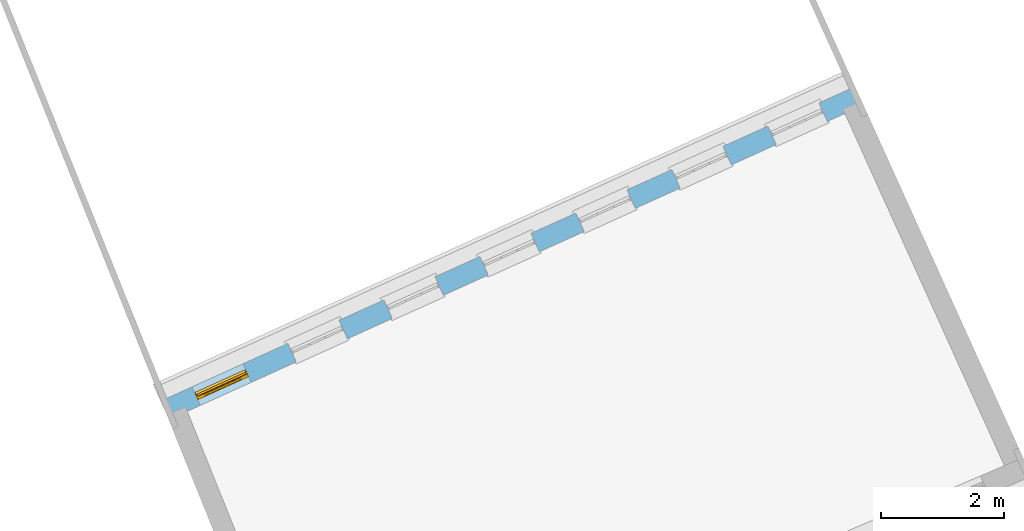
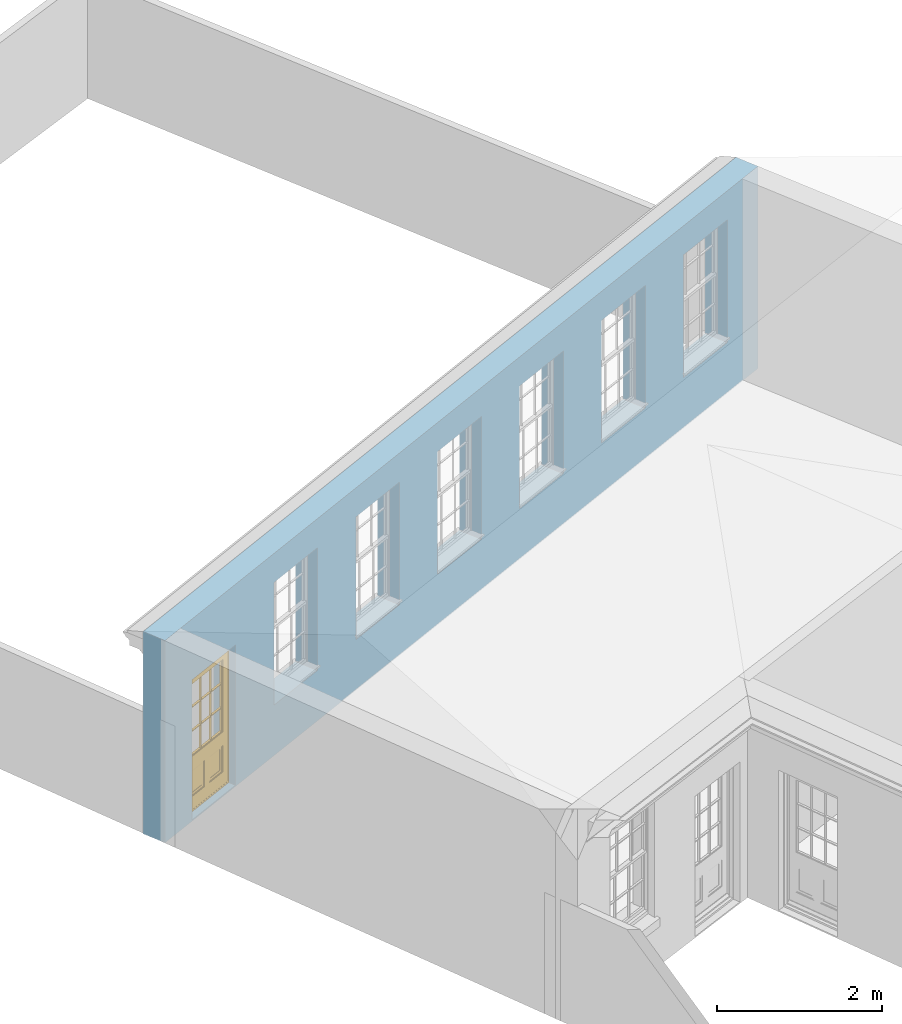
# One storey, part 17 of 19: 1 door, 7 openings, plus 1 element that does not belong to this part.
"""IFC2X3 building model written with IfcOpenShell, lengths in metres."""

from ifc_helpers import new_model, si_unit, frame, origin, place, context, subcontext, project, spatial, polyline, outline, extrude, faceted_brep, material, layer, layer_set, layer_usage, element, fill, save


model = new_model("IFC2X3")

# Units and contexts
model_context = context("Model", 3, world=origin())
body_context = subcontext(model_context, "Body", "Model", "MODEL_VIEW")
ifc_project = project(units=[si_unit("PLANEANGLEUNIT", "RADIAN"), si_unit("MASSUNIT", "GRAM", prefix="KILO"), si_unit("FORCEUNIT", "NEWTON", prefix="KILO"), si_unit("LENGTHUNIT", "METRE")], contexts=[model_context])

# Site, building, storey
site_placement = place(None, origin())
site = spatial("IfcSite", under=ifc_project, at=site_placement, CompositionType="ELEMENT")
building_placement = place(None, origin())
building = spatial("IfcBuilding", under=site, at=building_placement, Name="Building plot-0", CompositionType="ELEMENT")
storey_placement = place(None, origin())
storey = spatial("IfcBuildingStorey", under=building, at=storey_placement, Name="Floor 0", CompositionType="ELEMENT", Elevation=0.0)

# Wall, openings, door
ifc_material = material(Name="Masonry")
ifc_layer = layer(ifc_material, 0.33, ventilated=False)
ifc_layer_set = layer_set([ifc_layer], Name="My Wall")
ifc_layer_usage = layer_usage(ifc_layer_set, "AXIS2", "NEGATIVE", 0.08)
wall_placement = place(storey_placement, origin())
wall = element("IfcWallStandardCase", 1, at=wall_placement, inside=storey, material=ifc_layer_usage, Name="exterior", context=body_context, shape_type="SweptSolid", body=[
    extrude(outline(polyline([(21.5007118437475, 40.3889268355029), (21.3645733407012, 40.6895367288669), (10.0949852202286, 35.5858295970064), (10.2311237232749, 35.2852197036424), (21.5007118437475, 40.3889268355029)])), origin(), (0.0, 0.0, 1.0), 3.0),
])
opening_1_placement = place(storey_placement, frame((0.0, 0.0, 0.75)))
element("IfcOpeningElement", 2, at=opening_1_placement, cuts=wall, Name="Opening", ObjectType="Opening", context=body_context, shape_type="SweptSolid", body=[
    extrude(outline(polyline([(20.7788788084242, 40.4242907119302), (19.9499242539963, 40.048878476257), (20.0860627570426, 39.748268582893), (20.9150173114706, 40.1236808185662), (20.7788788084242, 40.4242907119302)])), origin(), (0.0, 0.0, 1.0), 1.82),
])
opening_2_placement = place(storey_placement, frame((0.0, 0.0, 0.75)))
element("IfcOpeningElement", 3, at=opening_2_placement, cuts=wall, Name="Opening", ObjectType="Opening", context=body_context, shape_type="SweptSolid", body=[
    extrude(outline(polyline([(19.2211729973563, 39.7188457415993), (18.3922184429283, 39.3434335059261), (18.5283569459746, 39.0428236125621), (19.3573115004026, 39.4182358482353), (19.2211729973563, 39.7188457415993)])), origin(), (0.0, 0.0, 1.0), 1.82),
])
opening_3_placement = place(storey_placement, frame((0.0, 0.0, 0.75)))
element("IfcOpeningElement", 4, at=opening_3_placement, cuts=wall, Name="Opening", ObjectType="Opening", context=body_context, shape_type="SweptSolid", body=[
    extrude(outline(polyline([(17.6634671862884, 39.0134007712684), (16.8345126318604, 38.6379885355952), (16.9706511349067, 38.3373786422312), (17.7996056893347, 38.7127908779044), (17.6634671862884, 39.0134007712684)])), origin(), (0.0, 0.0, 1.0), 1.82),
])
opening_4_placement = place(storey_placement, frame((0.0, 0.0, 0.75)))
element("IfcOpeningElement", 5, at=opening_4_placement, cuts=wall, Name="Opening", ObjectType="Opening", context=body_context, shape_type="SweptSolid", body=[
    extrude(outline(polyline([(16.1057613752204, 38.3079558009375), (15.2768068207924, 37.9325435652643), (15.4129453238388, 37.6319336719003), (16.2418998782667, 38.0073459075735), (16.1057613752204, 38.3079558009375)])), origin(), (0.0, 0.0, 1.0), 1.82),
])
opening_5_placement = place(storey_placement, frame((0.0, 0.0, 0.75)))
element("IfcOpeningElement", 6, at=opening_5_placement, cuts=wall, Name="Opening", ObjectType="Opening", context=body_context, shape_type="SweptSolid", body=[
    extrude(outline(polyline([(14.5480555641525, 37.6025108306066), (13.7191010097245, 37.2270985949334), (13.8552395127708, 36.9264887015694), (14.6841940671988, 37.3019009372426), (14.5480555641525, 37.6025108306066)])), origin(), (0.0, 0.0, 1.0), 1.82),
])
opening_6_placement = place(storey_placement, frame((0.0, 0.0, 0.75)))
element("IfcOpeningElement", 7, at=opening_6_placement, cuts=wall, Name="Opening", ObjectType="Opening", context=body_context, shape_type="SweptSolid", body=[
    extrude(outline(polyline([(12.9903497530845, 36.8970658602757), (12.1613951986565, 36.5216536246025), (12.2975337017029, 36.2210437312385), (13.1264882561308, 36.5964559669117), (12.9903497530845, 36.8970658602757)])), origin(), (0.0, 0.0, 1.0), 1.82),
])
opening_7_placement = place(storey_placement, frame((0.0, 0.0, 0.02)))
opening_7 = element("IfcOpeningElement", 8, at=opening_7_placement, cuts=wall, Name="Opening", ObjectType="Opening", context=body_context, shape_type="SweptSolid", body=[
    extrude(outline(polyline([(11.4326439420166, 36.1916208899448), (10.6036893875886, 35.8162086542716), (10.7398278906349, 35.5155987609077), (11.5687824450629, 35.8910109965808), (11.4326439420166, 36.1916208899448)])), origin(), (0.0, 0.0, 1.0), 2.08),
])
door_placement = place(storey_placement, frame((11.5357791715971, 35.9638861222448, 0.02), z_axis=(0.0, 0.0, 1.0), x_axis=(-0.828954554427972, -0.375412235673167, 0.0)))
door = element("IfcDoor", 9, at=door_placement, inside=storey, Name="bedroom door", OverallHeight=2.08, OverallWidth=0.91, context=body_context, shape_type="Brep", held_by="IfcProductRepresentation", body=[
    faceted_brep([(0.545, -0.055, 0.265), (0.745, -0.055, 0.265), (0.745, -0.05, 0.265), (0.545, -0.05, 0.265), (0.745, -0.05, 0.58), (0.545, -0.05, 0.58), (0.545, -0.055, 0.58), (0.515, -0.06, 0.235), (0.775, -0.06, 0.235), (0.745, -0.055, 0.58), (0.515, -0.06, 0.61), (0.515, -0.065, 0.235), (0.775, -0.065, 0.235), (0.775, -0.06, 0.61), (0.515, -0.065, 0.61), (0.785, -0.065, 0.225), (0.505, -0.065, 0.225), (0.775, -0.065, 0.61), (0.505, -0.065, 0.62), (0.785, -0.065, 0.62), (0.505, -0.07, 0.225), (0.785, -0.07, 0.225), (0.505, -0.07, 0.62), (0.785, -0.07, 0.62), (0.883, -0.07, 0.075), (0.898, -0.07, 0.075), (0.405, -0.07, 0.62), (0.405, -0.07, 0.225), (0.027, -0.07, 0.075), (0.785, -0.07, 0.82), (0.125, -0.07, 0.82), (0.405, -0.065, 0.62), (0.405, -0.065, 0.225), (0.898, -0.07, 2.068), (0.027, -0.08, 0.075), (0.883, -0.08, 0.075), (0.125, -0.07, 0.225), (0.012, -0.07, 0.075), (0.785, -0.06, 0.82), (0.125, -0.06, 0.82), (0.125, -0.07, 0.62), (0.125, -0.065, 0.62), (0.395, -0.065, 0.61), (0.395, -0.065, 0.235), (0.125, -0.065, 0.225), (0.785, -0.07, 1.895), (0.027, -0.11, 0.045), (0.883, -0.11, 0.045), (0.558333, -0.06, 0.83), (0.351667, -0.06, 0.83), (0.125, -0.07, 1.895), (0.125, -0.06, 1.895), (0.785, -0.06, 1.895), (0.012, -0.07, 2.068), (0.135, -0.065, 0.61), (0.395, -0.06, 0.61), (0.395, -0.06, 0.235), (0.135, -0.065, 0.235), (0.027, -0.11, 0.027), (0.883, -0.11, 0.027), (0.568333, -0.06, 0.83), (0.558333, -0.03, 0.83), (0.351667, -0.03, 0.83), (0.341667, -0.06, 0.83), (0.135, -0.06, 1.185), (0.135, -0.06, 1.53), (0.775, -0.06, 1.53), (0.775, -0.06, 1.185), (0.135, -0.06, 0.61), (0.365, -0.055, 0.58), (0.365, -0.055, 0.265), (0.135, -0.06, 0.235), (0.568333, -0.06, 1.175), (0.558333, -0.06, 1.175), (0.775, -0.06, 0.83), (0.558333, -0.03, 1.175), (0.785, -0.03, 0.82), (0.125, -0.03, 0.82), (0.351667, -0.03, 1.175), (0.351667, -0.06, 1.175), (0.341667, -0.06, 1.175), (0.135, -0.06, 0.83), (0.135, -0.06, 1.175), (0.135, -0.03, 1.185), (0.135, -0.03, 1.53), (0.135, -0.06, 1.54), (0.351667, -0.06, 1.885), (0.558333, -0.06, 1.885), (0.775, -0.03, 1.53), (0.775, -0.03, 1.185), (0.775, -0.06, 1.175), (0.775, -0.06, 1.54), (0.165, -0.055, 0.58), (0.365, -0.05, 0.58), (0.365, -0.05, 0.265), (0.165, -0.055, 0.265), (0.568333, -0.03, 0.83), (0.568333, -0.03, 1.175), (0.568333, -0.06, 1.185), (0.558333, -0.06, 1.185), (0.775, -0.03, 0.83), (0.785, -0.02, 0.82), (0.125, -0.02, 0.82), (0.341667, -0.03, 0.83), (0.341667, -0.03, 1.175), (0.351667, -0.06, 1.185), (0.341667, -0.06, 1.185), (0.135, -0.03, 0.83), (0.341667, -0.03, 1.185), (0.125, -0.03, 1.895), (0.341667, -0.03, 1.53), (0.341667, -0.06, 1.53), (0.135, -0.06, 1.885), (0.341667, -0.06, 1.54), (0.341667, -0.06, 1.885), (0.558333, -0.03, 1.885), (0.351667, -0.03, 1.885), (0.568333, -0.06, 1.885), (0.785, -0.03, 1.895), (0.568333, -0.03, 1.185), (0.568333, -0.06, 1.53), (0.568333, -0.03, 1.53), (0.568333, -0.06, 1.54), (0.775, -0.06, 1.885), (0.165, -0.05, 0.58), (0.165, -0.05, 0.265), (0.775, -0.03, 1.175), (0.558333, -0.06, 1.53), (0.351667, -0.03, 1.185), (0.558333, -0.03, 1.185), (0.505, -0.02, 0.62), (0.405, -0.02, 0.62), (0.125, -0.02, 1.895), (0.785, -0.02, 1.895), (0.351667, -0.06, 1.53), (0.135, -0.03, 1.175), (0.135, -0.03, 1.54), (0.341667, -0.03, 1.54), (0.135, -0.03, 1.885), (0.351667, -0.06, 1.54), (0.558333, -0.03, 1.54), (0.558333, -0.06, 1.54), (0.351667, -0.03, 1.54), (0.775, -0.03, 1.54), (0.568333, -0.03, 1.54), (0.775, -0.03, 1.885), (0.558333, -0.03, 1.53), (0.405, -0.02, 0.225), (0.505, -0.02, 0.225), (0.125, -0.02, 0.62), (0.785, -0.02, 0.62), (0.012, -0.02, 2.068), (0.898, -0.02, 2.068), (0.351667, -0.03, 1.53), (0.341667, -0.03, 1.885), (0.568333, -0.03, 1.885), (0.405, -0.025, 0.225), (0.405, -0.025, 0.62), (0.505, -0.025, 0.62), (0.505, -0.025, 0.225), (0.898, -0.02, 0.027), (0.012, -0.02, 0.027), (0.125, -0.025, 0.62), (0.785, -0.025, 0.62), (0.395, -0.025, 0.235), (0.395, -0.025, 0.61), (0.125, -0.02, 0.225), (0.125, -0.025, 0.225), (0.515, -0.025, 0.61), (0.515, -0.025, 0.235), (0.785, -0.02, 0.225), (0.785, -0.025, 0.225), (0.135, -0.025, 0.61), (0.775, -0.025, 0.61), (0.135, -0.025, 0.235), (0.395, -0.03, 0.235), (0.395, -0.03, 0.61), (0.515, -0.03, 0.61), (0.515, -0.03, 0.235), (0.775, -0.025, 0.235), (0.135, -0.03, 0.61), (0.775, -0.03, 0.61), (0.135, -0.03, 0.235), (0.365, -0.035, 0.265), (0.365, -0.035, 0.58), (0.545, -0.035, 0.58), (0.545, -0.035, 0.265), (0.775, -0.03, 0.235), (0.165, -0.035, 0.58), (0.745, -0.035, 0.58), (0.165, -0.035, 0.265), (0.365, -0.04, 0.58), (0.365, -0.04, 0.265), (0.545, -0.04, 0.58), (0.545, -0.04, 0.265), (0.745, -0.035, 0.265), (0.165, -0.04, 0.58), (0.745, -0.04, 0.58), (0.165, -0.04, 0.265), (0.745, -0.04, 0.265), (0.885, -0.072, 0.025), (0.025, -0.072, 0.025), (0.025, -0.1, 0.025), (0.885, -0.1, 0.025), (0.9, -0.02, 0.025), (0.01, -0.02, 0.025), (0.9, -0.072, 0.025), (0.91, -0.02, 0.0), (0.0, -0.02, 0.0), (0.01, -0.072, 0.025), (0.9, -0.072, 2.07), (0.9, -0.02, 2.07), (0.885, -0.072, 2.055), (0.91, -0.02, 2.08), (0.01, -0.02, 2.07), (0.0, -0.02, 2.08), (0.01, -0.072, 2.07), (0.025, -0.072, 2.055), (0.0, -0.15, 2.08), (0.91, -0.15, 2.08), (0.01, -0.15, 2.07), (0.9, -0.15, 2.07), (0.01, -0.1, 2.07), (0.9, -0.1, 2.07), (0.0, -0.15, 0.0), (0.91, -0.15, 0.0), (0.01, -0.15, 0.025), (0.9, -0.15, 0.025), (0.01, -0.1, 0.025), (0.025, -0.1, 2.055), (0.9, -0.1, 0.025), (0.885, -0.1, 2.055), (0.898, -0.07, 0.027), (0.012, -0.07, 0.027), (0.883, -0.07, 0.027), (0.027, -0.07, 0.027)], [[[0, 1, 2, 3]], [[2, 4, 5, 3]], [[0, 3, 5, 6]], [[1, 0, 7, 8]], [[9, 4, 2, 1]], [[9, 6, 5, 4]], [[0, 6, 10, 7]], [[8, 7, 11, 12]], [[8, 13, 9, 1]], [[13, 10, 6, 9]], [[7, 10, 14, 11]], [[15, 12, 11, 16]], [[12, 17, 13, 8]], [[17, 14, 10, 13]], [[18, 16, 11, 14]], [[15, 19, 17, 12]], [[15, 16, 20, 21]], [[14, 17, 19, 18]], [[16, 18, 22, 20]], [[21, 23, 19, 15]], [[24, 25, 21, 20]], [[23, 22, 18, 19]], [[20, 22, 26, 27]], [[23, 21, 25]], [[28, 24, 20, 27]], [[22, 23, 29]], [[29, 30, 26, 22]], [[27, 26, 31, 32]], [[23, 25, 33, 29]], [[34, 35, 24, 28]], [[28, 27, 36, 37]], [[38, 39, 30, 29]], [[26, 30, 40]], [[26, 40, 41, 31]], [[42, 43, 32, 31]], [[32, 44, 36, 27]], [[33, 45, 29]], [[46, 47, 35, 34]], [[36, 40, 37]], [[39, 38, 48, 49]], [[50, 30, 39, 51]], [[29, 45, 52, 38]], [[53, 37, 40, 30]], [[44, 41, 40, 36]], [[31, 41, 54, 42]], [[43, 42, 55, 56]], [[57, 44, 32, 43]], [[50, 45, 33, 53]], [[47, 46, 58, 59]], [[60, 48, 38]], [[49, 48, 61, 62]], [[49, 63, 39]], [[50, 53, 30]], [[51, 39, 64, 65]], [[45, 50, 51, 52]], [[66, 67, 38, 52]], [[57, 54, 41, 44]], [[42, 54, 68, 55]], [[56, 55, 69, 70]], [[56, 71, 57, 43]], [[60, 72, 73, 48]], [[60, 38, 74]], [[48, 73, 75, 61]], [[76, 77, 62, 61]], [[62, 78, 79, 49]], [[49, 79, 80, 63]], [[63, 81, 39]], [[82, 64, 39]], [[65, 64, 83, 84]], [[85, 51, 65]], [[52, 51, 86, 87]], [[88, 89, 67, 66]], [[90, 38, 67]], [[91, 66, 52]], [[71, 68, 54, 57]], [[55, 68, 92, 69]], [[69, 93, 94, 70]], [[70, 95, 71, 56]], [[96, 97, 72, 60]], [[73, 72, 98, 99]], [[74, 38, 90]], [[100, 96, 60, 74]], [[75, 73, 79, 78]], [[61, 75, 97, 96]], [[101, 102, 77, 76]], [[77, 103, 62]], [[96, 76, 61]], [[103, 104, 78, 62]], [[80, 79, 105, 106]], [[63, 80, 104, 103]], [[81, 63, 103, 107]], [[81, 82, 39]], [[106, 64, 82, 80]], [[106, 108, 83, 64]], [[84, 83, 77, 109]], [[110, 111, 65, 84]], [[112, 51, 85]], [[113, 85, 65, 111]], [[114, 86, 51]], [[115, 87, 86, 116]], [[117, 52, 87]], [[118, 76, 89, 88]], [[119, 98, 67, 89]], [[120, 121, 88, 66]], [[67, 98, 72, 90]], [[91, 122, 120, 66]], [[91, 52, 123]], [[95, 92, 68, 71]], [[69, 92, 124, 93]], [[94, 93, 124, 125]], [[94, 125, 95, 70]], [[72, 97, 126, 90]], [[127, 99, 98, 120]], [[99, 105, 79, 73]], [[74, 90, 126, 100]], [[96, 100, 76]], [[128, 129, 75, 78]], [[97, 75, 129, 119]], [[130, 131, 102, 101]], [[109, 77, 102, 132]], [[133, 101, 76, 118]], [[77, 107, 103]], [[78, 104, 108, 128]], [[111, 106, 105, 134]], [[104, 80, 82, 135]], [[107, 135, 82, 81]], [[110, 108, 106, 111]], [[104, 135, 83, 108]], [[83, 135, 77]], [[136, 84, 109]], [[110, 84, 136, 137]], [[114, 51, 112]], [[85, 136, 138, 112]], [[113, 137, 136, 85]], [[111, 134, 139, 113]], [[86, 114, 113, 139]], [[140, 141, 87, 115]], [[139, 142, 116, 86]], [[109, 118, 115, 116]], [[117, 123, 52]], [[117, 87, 141, 122]], [[126, 89, 76]], [[143, 118, 88]], [[120, 98, 119, 121]], [[119, 89, 126, 97]], [[144, 143, 88, 121]], [[144, 122, 91, 143]], [[127, 120, 122, 141]], [[143, 91, 123, 145]], [[124, 92, 95, 125]], [[146, 129, 99, 127]], [[99, 129, 128, 105]], [[100, 126, 76]], [[121, 119, 129, 146]], [[147, 131, 130, 148]], [[131, 149, 102]], [[130, 101, 150]], [[102, 151, 132]], [[118, 109, 132, 133]], [[101, 133, 152]], [[107, 77, 135]], [[153, 128, 108, 110]], [[134, 105, 128, 153]], [[109, 138, 136]], [[153, 110, 137, 142]], [[154, 114, 112, 138]], [[137, 113, 114, 154]], [[141, 139, 134, 127]], [[141, 140, 142, 139]], [[144, 140, 115, 155]], [[142, 137, 154, 116]], [[155, 115, 118]], [[116, 154, 109]], [[117, 155, 145, 123]], [[122, 144, 155, 117]], [[143, 145, 118]], [[121, 146, 140, 144]], [[146, 127, 134, 153]], [[156, 157, 131, 147]], [[148, 130, 158, 159]], [[148, 160, 161, 147]], [[157, 162, 149, 131]], [[161, 151, 102, 149]], [[101, 152, 160, 150]], [[163, 158, 130, 150]], [[151, 152, 133, 132]], [[154, 138, 109]], [[142, 140, 146, 153]], [[145, 155, 118]], [[157, 156, 164, 165]], [[147, 166, 167, 156]], [[168, 169, 159, 158]], [[170, 148, 159, 171]], [[148, 170, 160]], [[166, 147, 161]], [[172, 162, 157, 165]], [[166, 149, 162, 167]], [[166, 161, 149]], [[150, 160, 170]], [[163, 173, 168, 158]], [[171, 163, 150, 170]], [[174, 164, 156, 167]], [[175, 176, 165, 164]], [[169, 168, 177, 178]], [[171, 159, 169, 179]], [[167, 162, 172, 174]], [[176, 180, 172, 165]], [[179, 173, 163, 171]], [[181, 177, 168, 173]], [[164, 174, 182, 175]], [[183, 184, 176, 175]], [[178, 177, 185, 186]], [[179, 169, 178, 187]], [[174, 172, 180, 182]], [[184, 188, 180, 176]], [[187, 181, 173, 179]], [[189, 185, 177, 181]], [[175, 182, 190, 183]], [[191, 184, 183, 192]], [[185, 193, 194, 186]], [[187, 178, 186, 195]], [[182, 180, 188, 190]], [[191, 196, 188, 184]], [[195, 189, 181, 187]], [[197, 193, 185, 189]], [[183, 190, 198, 192]], [[198, 196, 191, 192]], [[194, 193, 197, 199]], [[195, 186, 194, 199]], [[188, 196, 198, 190]], [[197, 189, 195, 199]], [[200, 201, 202, 203]], [[201, 200, 204, 205]], [[206, 204, 200]], [[204, 207, 208, 205]], [[209, 201, 205]], [[210, 211, 204, 206]], [[206, 200, 212, 210]], [[211, 213, 207, 204]], [[214, 205, 208, 215]], [[216, 217, 201, 209]], [[205, 214, 216, 209]], [[216, 214, 211, 210]], [[210, 212, 217, 216]], [[214, 215, 213, 211]], [[218, 219, 213, 215]], [[219, 218, 220, 221]], [[221, 220, 222, 223]], [[215, 208, 224, 218]], [[225, 224, 208, 207]], [[224, 226, 220, 218]], [[224, 225, 227, 226]], [[219, 225, 207, 213]], [[228, 222, 220, 226]], [[219, 221, 227, 225]], [[226, 227, 203, 202]], [[202, 229, 222, 228]], [[228, 226, 202]], [[227, 221, 223, 230]], [[230, 203, 227]], [[217, 229, 202, 201]], [[231, 223, 222, 229]], [[230, 223, 231, 203]], [[231, 229, 217, 212]], [[212, 200, 203, 231]], [[33, 152, 151, 53]], [[25, 160, 152, 33]], [[161, 37, 53, 151]], [[232, 160, 25]], [[161, 233, 37]], [[160, 232, 234]], [[24, 234, 232, 25]], [[233, 161, 235]], [[37, 233, 235, 28]], [[161, 160, 234, 235]], [[35, 47, 234, 24]], [[28, 235, 46, 34]], [[58, 235, 234, 59]], [[59, 234, 47]], [[58, 46, 235]]]),
])
fill(opening_7, door)

save(model, "model.ifc")
